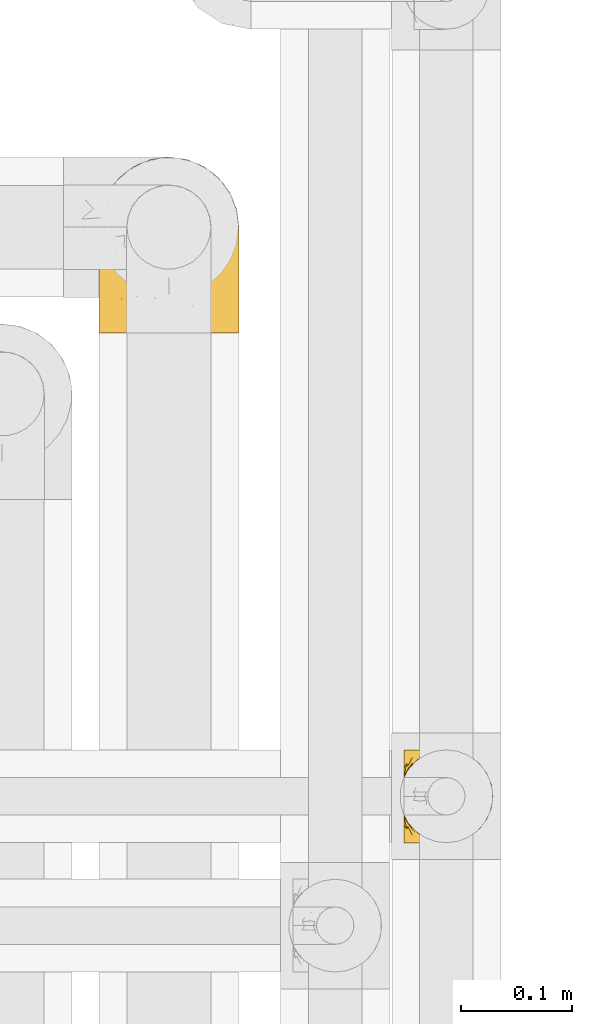
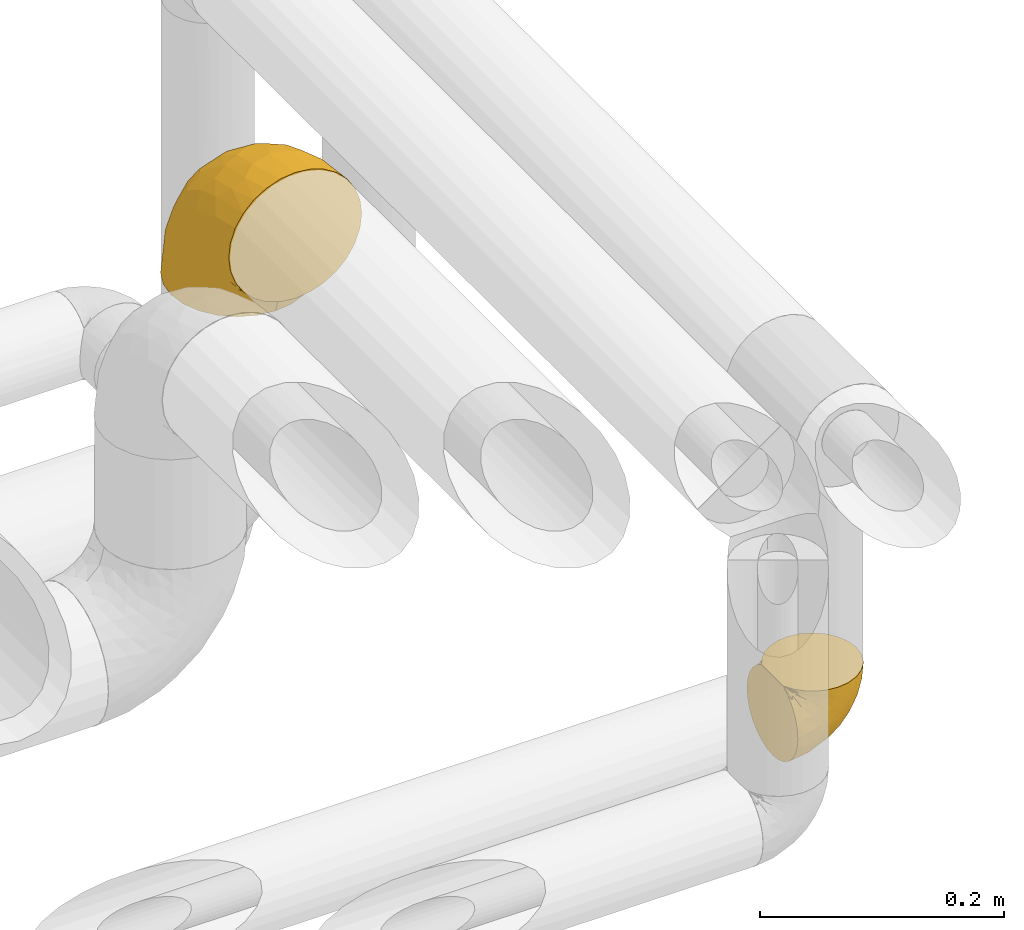
# One storey, part 493 of 827: 2 coverings.
"""IFC2X3 building model written with IfcOpenShell, lengths in millimetres."""

from ifc_helpers import new_model, entity, si_unit, converted_unit, derived_unit, direction, frame, origin, place, context, subcontext, project, spatial, faceted_brep, element, save


model = new_model("IFC2X3")

# Units and contexts
model_context = context("Model", 3, precision=0.01, world=origin(), true_north=direction((6.12303176911189e-17, 1.0)))
body_context = subcontext(model_context, "Body", "Model", "MODEL_VIEW")
ifc_project = project(units=[si_unit("LENGTHUNIT", "METRE", prefix="MILLI"), si_unit("AREAUNIT", "SQUARE_METRE"), si_unit("VOLUMEUNIT", "CUBIC_METRE"), converted_unit("PLANEANGLEUNIT", "DEGREE", entity("IfcRatioMeasure", 0.0174532925199433), si_unit("PLANEANGLEUNIT", "RADIAN"), dimensions=[0, 0, 0, 0, 0, 0, 0]), si_unit("MASSUNIT", "GRAM", prefix="KILO"), derived_unit("MASSDENSITYUNIT", [(si_unit("MASSUNIT", "GRAM", prefix="KILO"), 1), (si_unit("LENGTHUNIT", "METRE"), -3)]), derived_unit("MOMENTOFINERTIAUNIT", [(si_unit("LENGTHUNIT", "METRE"), 4)]), si_unit("TIMEUNIT", "SECOND"), si_unit("FREQUENCYUNIT", "HERTZ"), si_unit("THERMODYNAMICTEMPERATUREUNIT", "DEGREE_CELSIUS"), derived_unit("THERMALTRANSMITTANCEUNIT", [(si_unit("MASSUNIT", "GRAM", prefix="KILO"), 1), (si_unit("THERMODYNAMICTEMPERATUREUNIT", "KELVIN"), -1), (si_unit("TIMEUNIT", "SECOND"), -3)]), derived_unit("VOLUMETRICFLOWRATEUNIT", [(si_unit("LENGTHUNIT", "METRE"), 3), (si_unit("TIMEUNIT", "SECOND"), -1)]), derived_unit("MASSFLOWRATEUNIT", [(si_unit("MASSUNIT", "GRAM", prefix="KILO"), 1), (si_unit("TIMEUNIT", "SECOND"), -1)]), derived_unit("ROTATIONALFREQUENCYUNIT", [(si_unit("TIMEUNIT", "SECOND"), -1)]), si_unit("ELECTRICCURRENTUNIT", "AMPERE"), si_unit("ELECTRICVOLTAGEUNIT", "VOLT"), si_unit("POWERUNIT", "WATT"), si_unit("FORCEUNIT", "NEWTON", prefix="KILO"), si_unit("ILLUMINANCEUNIT", "LUX"), si_unit("LUMINOUSFLUXUNIT", "LUMEN"), si_unit("LUMINOUSINTENSITYUNIT", "CANDELA"), derived_unit("USERDEFINED", [(si_unit("MASSUNIT", "GRAM", prefix="KILO"), -1), (si_unit("LENGTHUNIT", "METRE"), -2), (si_unit("TIMEUNIT", "SECOND"), 3), (si_unit("LUMINOUSFLUXUNIT", "LUMEN"), 1)]), derived_unit("LINEARVELOCITYUNIT", [(si_unit("LENGTHUNIT", "METRE"), 1), (si_unit("TIMEUNIT", "SECOND"), -1)]), si_unit("PRESSUREUNIT", "PASCAL"), derived_unit("USERDEFINED", [(si_unit("LENGTHUNIT", "METRE"), -2), (si_unit("MASSUNIT", "GRAM", prefix="KILO"), 1), (si_unit("TIMEUNIT", "SECOND"), -2)]), derived_unit("LINEARFORCEUNIT", [(si_unit("MASSUNIT", "GRAM", prefix="KILO"), 1), (si_unit("LENGTHUNIT", "METRE"), 1), (si_unit("TIMEUNIT", "SECOND"), -2), (si_unit("LENGTHUNIT", "METRE"), -1)]), derived_unit("PLANARFORCEUNIT", [(si_unit("MASSUNIT", "GRAM", prefix="KILO"), 1), (si_unit("LENGTHUNIT", "METRE"), 1), (si_unit("TIMEUNIT", "SECOND"), -2), (si_unit("LENGTHUNIT", "METRE"), -2)])], contexts=[model_context])

# Site, building, storey
site_placement = place(None, origin())
site = spatial("IfcSite", under=ifc_project, at=site_placement, CompositionType="ELEMENT")
building_placement = place(site_placement, origin())
building = spatial("IfcBuilding", under=site, at=building_placement, CompositionType="ELEMENT")
storey_placement = place(building_placement, frame((0.0, 0.0, 28200.0)))
storey = spatial("IfcBuildingStorey", under=building, at=storey_placement, Name="08", CompositionType="ELEMENT", Elevation=28200.0)

# Coverings
covering_1_placement = place(storey_placement, frame((61113.04, 15517.08, 2656.55)))
element("IfcCovering", 1, at=covering_1_placement, inside=storey, Name=":ADSK_", ObjectType=":ADSK_", PredefinedType="INSULATION", context=body_context, shape_type="Brep", body=[
    faceted_brep([(1.6, 81.15, 25.28), (1.6, 76.16, 17.35), (1.6, 69.53, 10.72), (1.6, 61.6, 5.74), (1.6, 52.75, 2.64), (1.6, 43.45, 1.6), (1.6, 34.13, 2.65), (1.6, 25.28, 5.74), (1.6, 17.35, 10.73), (1.6, 10.72, 17.36), (1.6, 5.74, 25.29), (1.6, 2.64, 34.14), (1.6, 1.6, 43.45), (1.6, 2.66, 52.82), (1.6, 5.79, 61.71), (1.6, 10.83, 69.67), (1.6, 17.53, 76.31), (1.6, 25.53, 81.27), (1.6, 26.45, 81.27), (1.6, 27.37, 81.27), (1.6, 28.17, 81.27), (1.6, 29.49, 81.27), (1.6, 30.81, 81.27), (1.6, 32.13, 81.27), (1.6, 33.45, 81.27), (1.6, 34.78, 81.27), (1.6, 36.1, 81.27), (1.6, 37.42, 81.27), (1.6, 38.74, 81.27), (1.6, 40.06, 81.27), (1.6, 41.38, 81.27), (1.6, 42.7, 81.27), (1.6, 44.02, 81.27), (1.6, 45.34, 81.27), (1.6, 46.66, 81.27), (1.6, 47.58, 81.27), (1.6, 48.5, 81.27), (1.6, 49.41, 81.27), (1.6, 50.33, 81.27), (1.6, 51.25, 81.27), (1.6, 52.17, 81.27), (1.6, 53.09, 81.27), (1.6, 54.01, 81.27), (1.6, 54.93, 81.27), (1.6, 55.85, 81.27), (1.6, 56.76, 81.27), (1.6, 57.68, 81.27), (1.6, 58.6, 81.27), (1.6, 59.52, 81.27), (1.6, 60.44, 81.27), (1.6, 61.36, 81.27), (1.6, 69.37, 76.3), (1.6, 76.07, 69.66), (1.6, 81.11, 61.69), (1.6, 84.24, 52.8), (1.6, 85.3, 43.45), (1.6, 84.24, 34.13), (6.74, 17.52, 81.45), (13.37, 10.83, 81.45), (21.34, 5.79, 81.45), (30.23, 2.66, 81.45), (39.6, 1.6, 81.45), (50.43, 3.02, 81.45), (60.52, 7.2, 81.45), (69.19, 13.85, 81.45), (75.84, 22.52, 81.45), (80.02, 32.61, 81.45), (81.45, 43.45, 81.45), (80.02, 54.28, 81.45), (75.84, 64.37, 81.45), (69.19, 73.04, 81.45), (60.52, 79.69, 81.45), (50.43, 83.87, 81.45), (39.6, 85.3, 81.45), (30.23, 84.23, 81.45), (21.34, 81.1, 81.45), (13.37, 76.06, 81.45), (6.74, 69.37, 81.45), (1.77, 61.36, 81.45), (1.77, 60.44, 81.45), (1.77, 59.12, 81.45), (1.77, 58.0, 81.45), (1.77, 56.88, 81.45), (1.77, 55.76, 81.45), (1.77, 54.64, 81.45), (1.77, 53.52, 81.45), (1.77, 52.4, 81.45), (1.77, 51.28, 81.45), (1.77, 50.16, 81.45), (1.77, 49.04, 81.45), (1.77, 47.92, 81.45), (1.77, 46.8, 81.45), (1.77, 45.68, 81.45), (1.77, 44.56, 81.45), (1.77, 43.45, 81.45), (1.77, 42.12, 81.45), (1.77, 40.8, 81.45), (1.77, 39.48, 81.45), (1.77, 38.16, 81.45), (1.77, 36.84, 81.45), (1.77, 35.52, 81.45), (1.77, 34.2, 81.45), (1.77, 32.88, 81.45), (1.77, 31.96, 81.45), (1.77, 31.05, 81.45), (1.77, 30.13, 81.45), (1.77, 29.21, 81.45), (1.77, 28.29, 81.45), (1.77, 27.37, 81.45), (1.77, 26.45, 81.45), (1.77, 25.53, 81.45), (1.73, 54.08, 81.33), (1.72, 55.16, 81.32), (1.73, 36.18, 81.33), (1.72, 35.13, 81.32), (1.73, 44.01, 81.33), (1.73, 45.08, 81.32), (1.72, 61.36, 81.32), (1.72, 59.98, 81.32), (1.72, 46.18, 81.32), (1.72, 26.74, 81.32), (1.72, 47.36, 81.32), (1.73, 29.67, 81.32), (1.74, 28.72, 81.34), (1.72, 39.77, 81.32), (1.71, 52.96, 81.31), (1.73, 51.84, 81.33), (1.71, 40.8, 81.31), (1.72, 41.87, 81.32), (1.73, 42.94, 81.33), (1.72, 27.77, 81.32), (1.73, 48.4, 81.33), (1.72, 37.21, 81.32), (1.73, 33.54, 81.33), (1.72, 32.49, 81.32), (1.72, 30.69, 81.32), (1.72, 50.69, 81.32), (1.71, 49.6, 81.31), (1.72, 56.32, 81.32), (1.73, 57.44, 81.33), (1.71, 58.88, 81.31), (1.72, 25.53, 81.32), (1.68, 61.36, 81.3), (1.64, 61.36, 81.29), (1.64, 25.53, 81.29), (1.68, 25.53, 81.3), (1.75, 61.36, 81.4), (1.74, 61.36, 81.36), (1.74, 25.53, 81.36), (1.75, 25.53, 81.4), (1.7, 31.59, 81.3), (1.73, 38.71, 81.33), (24.54, 3.97, 74.06), (11.1, 1.6, 45.99), (8.47, 3.97, 58.35), (9.11, 8.09, 67.76), (4.86, 8.09, 66.18), (5.0, 16.43, 76.46), (6.81, 15.73, 77.33), (37.05, 1.6, 71.95), (9.03, 10.79, 72.25), (9.47, 13.99, 78.91), (16.39, 8.08, 76.42), (3.95, 14.0, 73.52), (9.9, 12.83, 76.9), (22.7, 3.18, 65.25), (34.5, 1.6, 62.45), (37.68, 1.6, 74.31), (15.82, 3.28, 59.38), (20.6, 1.6, 48.54), (14.37, 6.28, 67.72), (27.55, 1.6, 55.49), (5.2, 19.06, 79.73), (14.88, 8.08, 73.23), (8.73, 1.6, 45.36), (44.27, 32.11, 15.81), (20.94, 29.62, 6.4), (32.15, 43.45, 7.67), (46.13, 2.45, 68.46), (42.67, 2.5, 59.33), (55.18, 9.73, 48.7), (67.27, 17.97, 53.94), (62.91, 10.24, 65.02), (51.5, 4.78, 60.77), (54.79, 4.78, 72.07), (25.78, 8.01, 26.25), (13.05, 8.01, 22.29), (18.46, 13.85, 16.0), (32.4, 2.42, 46.93), (31.07, 21.17, 14.19), (77.32, 35.73, 58.46), (75.62, 27.43, 61.51), (16.9, 43.45, 4.64), (71.69, 17.97, 68.93), (61.4, 35.71, 29.62), (54.47, 29.47, 24.85), (27.66, 3.41, 38.55), (14.53, 3.94, 31.27), (15.56, 21.17, 9.35), (42.26, 7.92, 37.15), (41.51, 4.25, 47.07), (36.93, 11.75, 26.49), (42.72, 18.31, 23.01), (44.68, 24.94, 19.4), (71.2, 28.78, 48.06), (70.48, 35.82, 42.46), (75.37, 43.45, 50.89), (63.65, 28.38, 35.78), (58.06, 43.45, 24.98), (45.11, 43.45, 16.33), (78.4, 43.45, 66.14), (54.95, 21.21, 30.96), (59.31, 16.48, 41.83), (49.01, 13.85, 33.28), (66.71, 43.45, 37.94), (53.75, 82.11, 67.39), (77.27, 51.41, 58.47), (61.6, 57.45, 32.5), (44.24, 54.78, 15.79), (18.46, 73.03, 15.99), (15.55, 65.7, 9.34), (60.14, 76.65, 56.91), (70.5, 68.92, 63.5), (63.0, 68.01, 44.08), (25.78, 78.88, 26.24), (13.05, 78.88, 22.27), (14.53, 82.94, 31.26), (48.5, 64.44, 23.95), (44.23, 84.49, 63.79), (34.5, 85.3, 62.45), (37.05, 85.3, 71.95), (8.73, 85.3, 45.36), (77.68, 57.84, 67.83), (64.08, 76.65, 70.28), (70.25, 51.19, 42.11), (20.93, 57.26, 6.39), (49.9, 78.14, 43.54), (49.6, 82.35, 58.03), (31.06, 65.7, 14.18), (39.62, 84.61, 56.34), (34.42, 84.36, 48.09), (20.6, 85.3, 48.54), (27.55, 85.3, 55.49), (33.36, 73.03, 21.78), (27.68, 83.48, 38.54), (11.1, 85.3, 45.99), (46.67, 84.54, 72.79), (49.0, 73.03, 33.26), (38.94, 79.54, 35.53), (73.05, 59.46, 53.66), (56.63, 73.5, 43.03), (43.85, 82.57, 49.68), (24.54, 82.92, 74.06), (15.82, 83.62, 59.37), (8.47, 82.92, 58.34), (9.12, 78.81, 67.75), (9.47, 72.9, 78.91), (9.91, 74.06, 76.9), (16.85, 78.81, 78.08), (14.88, 78.81, 73.23), (5.2, 67.83, 79.73), (6.81, 71.15, 77.34), (3.96, 72.91, 73.51), (5.0, 70.47, 76.45), (5.86, 78.81, 66.41), (14.38, 80.62, 67.7), (9.04, 76.11, 72.24), (22.7, 83.71, 65.25)], [[[0, 1, 2, 3, 4, 5, 6, 7, 8, 9, 10, 11, 12, 13, 14, 15, 16, 17, 18, 19, 20, 21, 22, 23, 24, 25, 26, 27, 28, 29, 30, 31, 32, 33, 34, 35, 36, 37, 38, 39, 40, 41, 42, 43, 44, 45, 46, 47, 48, 49, 50, 51, 52, 53, 54, 55, 56]], [[57, 58, 59, 60, 61, 62, 63, 64, 65, 66, 67, 68, 69, 70, 71, 72, 73, 74, 75, 76, 77, 78, 79, 80, 81, 82, 83, 84, 85, 86, 87, 88, 89, 90, 91, 92, 93, 94, 95, 96, 97, 98, 99, 100, 101, 102, 103, 104, 105, 106, 107, 108, 109, 110]], [[111, 84, 112]], [[113, 26, 114]], [[114, 101, 100]], [[115, 93, 116]], [[79, 117, 118]], [[33, 116, 119]], [[117, 49, 118]], [[19, 18, 120]], [[119, 121, 34]], [[122, 21, 123]], [[97, 96, 124]], [[86, 125, 126]], [[116, 92, 119]], [[127, 96, 128]], [[32, 129, 115]], [[19, 120, 130]], [[121, 90, 131]], [[94, 115, 129]], [[115, 116, 32]], [[118, 49, 48]], [[113, 99, 132]], [[133, 114, 25]], [[24, 134, 133]], [[135, 22, 122]], [[136, 137, 88]], [[84, 83, 112]], [[138, 82, 139]], [[130, 20, 19]], [[118, 48, 140]], [[81, 140, 139]], [[123, 21, 20]], [[141, 120, 18]], [[139, 82, 81]], [[130, 107, 123]], [[49, 117, 142, 143, 50]], [[18, 17, 144, 145, 141]], [[79, 78, 146, 147, 117]], [[109, 141, 148, 149, 110]], [[102, 133, 134]], [[105, 135, 122]], [[118, 80, 79]], [[80, 118, 140]], [[120, 109, 108]], [[47, 46, 140, 48]], [[81, 80, 140]], [[44, 112, 138]], [[93, 115, 94]], [[46, 139, 140]], [[46, 45, 139]], [[139, 45, 138]], [[138, 112, 83]], [[85, 84, 111]], [[112, 43, 111]], [[83, 82, 138]], [[106, 122, 123]], [[105, 122, 106]], [[21, 122, 22]], [[124, 29, 28]], [[33, 32, 116]], [[128, 129, 31]], [[32, 31, 129]], [[34, 33, 119]], [[116, 93, 92]], [[129, 95, 94]], [[95, 129, 128]], [[41, 40, 125, 42]], [[119, 91, 121]], [[36, 35, 131, 37]], [[137, 131, 89]], [[121, 131, 35]], [[90, 121, 91]], [[119, 92, 91]], [[136, 126, 39]], [[125, 86, 85]], [[42, 125, 111]], [[85, 111, 125]], [[150, 23, 22]], [[130, 108, 107]], [[130, 123, 20]], [[107, 106, 123]], [[137, 37, 131]], [[136, 38, 137]], [[89, 88, 137]], [[131, 90, 89]], [[124, 151, 97]], [[40, 39, 126]], [[87, 126, 136]], [[86, 126, 87]], [[136, 88, 87]], [[40, 126, 125]], [[39, 38, 136]], [[95, 128, 96]], [[30, 128, 31]], [[29, 124, 127]], [[127, 128, 30]], [[151, 124, 28]], [[127, 30, 29]], [[127, 124, 96]], [[151, 98, 97]], [[45, 44, 138]], [[26, 113, 132]], [[113, 100, 99]], [[132, 151, 27]], [[27, 26, 132]], [[26, 25, 114]], [[100, 113, 114]], [[101, 133, 102]], [[133, 101, 114]], [[28, 27, 151]], [[132, 99, 98]], [[23, 134, 24]], [[25, 24, 133]], [[134, 23, 150]], [[135, 104, 150]], [[150, 104, 103]], [[103, 102, 134]], [[130, 120, 108]], [[109, 120, 141]], [[42, 111, 43]], [[112, 44, 43]], [[104, 135, 105]], [[134, 150, 103]], [[135, 150, 22]], [[35, 34, 121]], [[137, 38, 37]], [[98, 151, 132]], [[59, 152, 60]], [[13, 153, 154]], [[155, 156, 154]], [[157, 158, 141]], [[159, 60, 152]], [[160, 157, 155]], [[161, 162, 58]], [[58, 162, 59]], [[144, 16, 163]], [[58, 57, 161]], [[162, 161, 164]], [[157, 163, 155]], [[163, 16, 15]], [[57, 149, 161]], [[152, 165, 166]], [[157, 144, 163]], [[60, 159, 167, 61]], [[156, 14, 154]], [[163, 156, 155]], [[155, 154, 168]], [[168, 154, 169]], [[155, 170, 160]], [[57, 110, 149]], [[144, 17, 16]], [[156, 15, 14]], [[171, 165, 168]], [[158, 164, 172]], [[14, 13, 154]], [[157, 141, 145, 144]], [[173, 164, 158]], [[173, 160, 170]], [[171, 166, 165]], [[168, 165, 170]], [[168, 169, 171]], [[152, 173, 165]], [[170, 155, 168]], [[165, 173, 170]], [[160, 173, 158]], [[172, 149, 148]], [[148, 141, 158]], [[158, 157, 160]], [[152, 166, 159]], [[173, 152, 162]], [[59, 162, 152]], [[13, 12, 174, 153]], [[153, 169, 154]], [[15, 156, 163]], [[162, 164, 173]], [[172, 164, 161]], [[149, 172, 161]], [[158, 172, 148]], [[175, 176, 177]], [[178, 166, 179]], [[180, 181, 182]], [[183, 184, 178]], [[185, 186, 187]], [[171, 188, 179]], [[174, 12, 11]], [[189, 176, 175]], [[190, 66, 191]], [[176, 6, 192]], [[193, 65, 64]], [[63, 184, 182]], [[63, 182, 64]], [[65, 193, 191]], [[184, 63, 62]], [[175, 194, 195]], [[196, 169, 197]], [[174, 11, 197]], [[8, 7, 198]], [[187, 9, 8]], [[197, 169, 153, 174]], [[197, 11, 10]], [[186, 197, 10]], [[199, 180, 200]], [[197, 185, 196]], [[201, 189, 202]], [[201, 187, 189]], [[195, 203, 175]], [[191, 204, 190]], [[176, 7, 6]], [[177, 176, 192]], [[189, 198, 176]], [[65, 191, 66]], [[198, 187, 8]], [[205, 206, 190]], [[9, 186, 10]], [[181, 207, 204]], [[208, 175, 177, 209]], [[66, 190, 210]], [[211, 212, 213]], [[190, 204, 205]], [[180, 182, 183]], [[193, 182, 181]], [[62, 61, 167]], [[196, 185, 199]], [[196, 200, 188]], [[6, 5, 192]], [[176, 198, 7]], [[187, 198, 189]], [[187, 186, 9]], [[197, 186, 185]], [[200, 180, 183]], [[180, 213, 212]], [[179, 183, 178]], [[185, 201, 199]], [[210, 190, 206]], [[210, 67, 66]], [[205, 204, 207]], [[194, 205, 207]], [[194, 214, 205]], [[195, 194, 207]], [[208, 194, 175]], [[207, 211, 195]], [[202, 203, 211]], [[212, 207, 181]], [[202, 211, 213]], [[201, 202, 213]], [[189, 175, 203]], [[199, 201, 213]], [[187, 201, 185]], [[180, 199, 213]], [[196, 199, 200]], [[211, 203, 195]], [[189, 203, 202]], [[207, 212, 211]], [[180, 212, 181]], [[214, 194, 208]], [[214, 206, 205]], [[196, 188, 169]], [[181, 204, 191]], [[182, 193, 64]], [[191, 193, 181]], [[178, 62, 167]], [[182, 184, 183]], [[62, 178, 184]], [[178, 167, 159, 166]], [[171, 179, 166]], [[200, 183, 179]], [[179, 188, 200]], [[169, 188, 171]], [[71, 215, 72]], [[206, 216, 210]], [[217, 208, 218]], [[216, 68, 210]], [[219, 220, 2]], [[221, 222, 223]], [[224, 225, 226]], [[227, 223, 217]], [[228, 229, 230]], [[56, 231, 226]], [[232, 222, 69]], [[56, 55, 231]], [[70, 233, 71]], [[71, 233, 215]], [[0, 56, 226]], [[208, 217, 234]], [[218, 177, 235]], [[221, 236, 237]], [[238, 220, 219]], [[1, 219, 2]], [[68, 216, 232]], [[235, 3, 220]], [[235, 192, 4]], [[1, 0, 225]], [[228, 239, 229]], [[240, 241, 242]], [[243, 238, 219]], [[224, 226, 244]], [[226, 241, 244]], [[3, 235, 4]], [[69, 222, 70]], [[225, 219, 1]], [[218, 235, 238]], [[243, 219, 224]], [[218, 227, 217]], [[3, 2, 220]], [[218, 208, 209, 177]], [[226, 231, 245, 241]], [[215, 228, 246]], [[247, 248, 236]], [[248, 224, 244]], [[223, 222, 249]], [[233, 222, 221]], [[242, 239, 240]], [[248, 247, 243]], [[217, 223, 249]], [[250, 247, 236]], [[216, 234, 249]], [[218, 238, 227]], [[192, 235, 177]], [[192, 5, 4]], [[72, 246, 73]], [[235, 220, 238]], [[226, 225, 0]], [[219, 225, 224]], [[240, 248, 244]], [[239, 242, 229]], [[236, 248, 251]], [[68, 67, 210]], [[234, 216, 206]], [[216, 249, 232]], [[234, 206, 214, 208]], [[249, 234, 217]], [[222, 232, 249]], [[69, 68, 232]], [[246, 228, 230]], [[237, 228, 215]], [[243, 227, 238]], [[223, 227, 247]], [[73, 246, 230]], [[215, 246, 72]], [[248, 243, 224]], [[227, 243, 247]], [[237, 236, 251]], [[250, 221, 223]], [[222, 233, 70]], [[215, 233, 221]], [[221, 237, 215]], [[239, 237, 251]], [[237, 239, 228]], [[239, 251, 240]], [[248, 240, 251]], [[241, 240, 244]], [[221, 250, 236]], [[223, 247, 250]], [[74, 230, 252]], [[253, 254, 255]], [[146, 77, 256]], [[257, 258, 259]], [[260, 256, 257]], [[260, 261, 147]], [[75, 74, 252]], [[51, 143, 262]], [[263, 143, 142, 117]], [[256, 77, 76]], [[252, 258, 75]], [[253, 241, 254]], [[254, 245, 54]], [[258, 256, 76]], [[53, 52, 264]], [[255, 265, 253]], [[254, 264, 255]], [[255, 264, 262]], [[75, 258, 76]], [[265, 255, 266]], [[255, 262, 263]], [[51, 50, 143]], [[54, 245, 231, 55]], [[51, 262, 52]], [[253, 267, 242]], [[254, 54, 53]], [[266, 259, 265]], [[146, 78, 77]], [[263, 117, 261]], [[146, 256, 260]], [[257, 259, 261]], [[267, 253, 265]], [[229, 267, 252]], [[242, 267, 229]], [[242, 241, 253]], [[252, 267, 259]], [[255, 263, 266]], [[259, 267, 265]], [[261, 117, 147]], [[263, 261, 266]], [[259, 266, 261]], [[230, 74, 73]], [[230, 229, 252]], [[259, 258, 252]], [[254, 241, 245]], [[53, 264, 254]], [[52, 262, 264]], [[143, 263, 262]], [[258, 257, 256]], [[261, 260, 257]], [[146, 260, 147]]]),
])
covering_2_placement = place(storey_placement, frame((60838.46, 15975.78, 2903.4)))
element("IfcCovering", 2, at=covering_2_placement, inside=storey, Name=":ADSK_", ObjectType=":ADSK_", PredefinedType="INSULATION", context=body_context, shape_type="Brep", body=[
    faceted_brep([(92.0, 1.6, 153.4), (78.68, 1.6, 158.06), (64.65, 1.6, 159.65), (50.62, 1.6, 158.06), (37.29, 1.6, 153.4), (25.34, 1.6, 145.89), (15.35, 1.6, 135.91), (7.84, 1.6, 123.95), (3.18, 1.6, 110.63), (1.6, 1.6, 96.6), (3.18, 1.6, 82.57), (7.84, 1.6, 69.24), (15.35, 1.6, 57.29), (25.33, 1.6, 47.3), (37.29, 1.6, 39.79), (50.61, 1.6, 35.13), (64.65, 1.6, 33.55), (78.67, 1.6, 35.13), (92.0, 1.6, 39.79), (103.95, 1.6, 47.3), (113.94, 1.6, 57.28), (121.45, 1.6, 69.24), (126.11, 1.6, 82.56), (127.7, 1.6, 96.6), (126.11, 1.6, 110.62), (121.45, 1.6, 123.95), (113.94, 1.6, 135.9), (103.96, 1.6, 145.89), (64.65, 33.55, 1.6), (48.33, 35.69, 1.6), (33.12, 41.99, 1.6), (20.06, 52.01, 1.6), (10.04, 65.07, 1.6), (3.74, 80.28, 1.6), (3.01, 85.89, 1.6), (1.6, 96.6, 1.6), (3.74, 112.91, 1.6), (10.04, 128.12, 1.6), (20.06, 141.18, 1.6), (33.12, 151.2, 1.6), (48.33, 157.5, 1.6), (64.65, 159.65, 1.6), (80.96, 157.5, 1.6), (96.17, 151.2, 1.6), (109.23, 141.18, 1.6), (119.25, 128.12, 1.6), (125.55, 112.91, 1.6), (127.7, 96.6, 1.6), (126.29, 85.89, 1.6), (125.55, 80.28, 1.6), (119.25, 65.07, 1.6), (109.23, 52.01, 1.6), (96.17, 41.99, 1.6), (80.96, 35.69, 1.6), (101.1, 145.23, 30.13), (86.72, 150.95, 39.4), (98.7, 136.48, 62.65), (75.93, 156.3, 28.52), (64.65, 154.26, 42.5), (113.39, 73.92, 115.57), (111.06, 98.94, 98.94), (96.87, 102.72, 111.29), (84.07, 124.89, 95.5), (64.65, 138.47, 80.62), (64.65, 113.35, 113.35), (119.56, 120.33, 43.71), (112.75, 118.42, 70.76), (122.85, 103.99, 62.71), (125.08, 110.05, 33.16), (126.64, 94.6, 53.41), (105.78, 62.68, 130.65), (93.81, 66.8, 137.68), (96.07, 37.71, 146.84), (87.11, 141.12, 66.58), (75.77, 148.29, 57.7), (111.99, 132.76, 39.88), (64.65, 42.5, 154.26), (83.58, 39.36, 152.07), (80.96, 96.16, 125.54), (78.34, 69.16, 142.81), (122.85, 62.71, 103.99), (125.88, 79.4, 79.4), (120.97, 88.81, 88.81), (126.67, 26.93, 104.86), (122.64, 32.13, 117.38), (127.7, 78.45, 57.43), (127.7, 85.2, 44.19), (127.7, 91.95, 30.95), (107.12, 31.66, 139.96), (115.07, 45.38, 127.03), (102.81, 118.88, 87.17), (127.7, 57.43, 78.45), (127.7, 62.69, 73.2), (127.7, 67.94, 67.94), (127.7, 13.99, 94.63), (127.7, 22.47, 93.29), (127.7, 30.95, 91.95), (126.64, 53.41, 94.6), (127.7, 44.19, 85.2), (64.65, 80.62, 138.47), (127.7, 94.63, 13.99), (113.05, 39.95, 40.46), (101.81, 33.15, 32.36), (108.46, 43.2, 28.71), (126.21, 81.77, 15.53), (122.65, 66.3, 29.06), (126.55, 75.23, 40.03), (125.45, 66.55, 45.36), (126.01, 78.18, 26.46), (123.3, 56.85, 47.56), (118.99, 54.23, 36.28), (113.51, 12.94, 55.57), (104.6, 17.42, 45.02), (118.04, 27.05, 57.55), (101.6, 44.37, 11.56), (109.98, 49.66, 19.2), (92.1, 38.88, 10.07), (96.28, 37.08, 21.04), (121.05, 66.96, 15.52), (79.4, 32.99, 13.84), (79.19, 14.52, 32.67), (80.39, 26.32, 24.86), (93.14, 22.37, 34.31), (126.75, 27.96, 81.47), (125.71, 39.47, 71.26), (126.17, 15.41, 81.64), (64.65, 17.57, 29.26), (123.28, 21.31, 70.65), (64.65, 7.61, 31.93), (91.58, 28.92, 27.99), (107.1, 28.65, 41.71), (116.28, 34.82, 50.14), (116.32, 58.27, 17.57), (90.34, 11.73, 37.62), (122.74, 40.36, 60.48), (64.65, 29.26, 17.57), (126.77, 65.12, 56.96), (119.84, 45.4, 48.98), (124.71, 53.05, 57.29), (126.47, 50.39, 68.25), (37.19, 38.88, 10.07), (27.66, 42.9, 16.58), (49.9, 32.99, 13.84), (1.6, 94.63, 13.99), (50.1, 14.52, 32.67), (48.89, 26.32, 24.86), (2.88, 50.51, 67.81), (6.55, 39.41, 61.09), (3.58, 39.47, 71.26), (1.6, 78.45, 57.43), (1.6, 85.2, 44.19), (2.74, 75.23, 40.03), (11.25, 27.05, 57.55), (11.93, 36.34, 51.01), (21.09, 28.89, 42.79), (3.28, 78.18, 26.46), (6.64, 66.3, 29.06), (12.97, 58.27, 17.57), (19.31, 49.66, 19.2), (16.23, 39.95, 40.46), (21.44, 42.42, 28.84), (26.96, 32.56, 33.48), (8.24, 66.96, 15.52), (3.08, 81.77, 15.53), (10.3, 54.23, 36.28), (38.95, 11.73, 37.62), (33.01, 37.08, 21.04), (1.6, 13.99, 94.63), (1.6, 22.47, 93.29), (36.15, 22.37, 34.31), (24.69, 17.42, 45.03), (6.01, 21.32, 70.65), (2.54, 27.96, 81.47), (15.78, 12.94, 55.58), (1.6, 30.95, 91.95), (3.12, 15.41, 81.64), (37.33, 29.3, 27.86), (1.6, 57.43, 78.45), (1.6, 44.19, 85.2), (2.52, 65.12, 56.96), (3.84, 66.55, 45.36), (5.99, 56.85, 47.57), (9.35, 46.41, 48.27), (1.6, 67.94, 67.94), (4.58, 53.04, 57.3), (1.6, 91.95, 30.95), (30.59, 136.48, 62.65), (28.19, 145.23, 30.13), (17.3, 132.76, 39.88), (9.73, 120.33, 43.71), (42.57, 150.95, 39.4), (53.51, 149.01, 55.79), (53.42, 156.33, 28.41), (2.65, 94.6, 53.41), (2.62, 26.93, 104.86), (6.66, 32.14, 117.39), (6.44, 62.71, 103.99), (48.33, 96.16, 125.54), (32.42, 102.72, 111.29), (35.49, 66.79, 137.69), (2.65, 53.41, 94.6), (3.41, 79.4, 79.4), (4.21, 110.05, 33.16), (43.07, 140.44, 68.78), (23.52, 62.68, 130.66), (22.18, 31.66, 139.97), (33.1, 29.31, 148.6), (15.9, 73.92, 115.58), (14.23, 45.39, 127.03), (16.54, 118.42, 70.76), (45.22, 124.89, 95.5), (6.44, 103.99, 62.71), (8.33, 88.81, 88.81), (18.23, 98.94, 98.94), (32.99, 122.85, 89.09), (53.35, 138.38, 78.72), (48.76, 69.18, 142.21), (45.72, 39.36, 152.07)], [[[0, 1, 2, 3, 4, 5, 6, 7, 8, 9, 10, 11, 12, 13, 14, 15, 16, 17, 18, 19, 20, 21, 22, 23, 24, 25, 26, 27]], [[28, 29, 30, 31, 32, 33, 34, 35, 36, 37, 38, 39, 40, 41, 42, 43, 44, 45, 46, 47, 48, 49, 50, 51, 52, 53]], [[54, 55, 56]], [[57, 41, 58]], [[59, 60, 61]], [[62, 63, 64]], [[65, 66, 67]], [[68, 67, 69]], [[70, 71, 72]], [[55, 73, 56]], [[43, 42, 55]], [[55, 74, 73]], [[44, 75, 45]], [[44, 43, 54]], [[76, 1, 77]], [[71, 78, 79]], [[45, 75, 65]], [[46, 68, 47]], [[80, 81, 82]], [[24, 83, 84]], [[69, 85, 86, 87]], [[69, 81, 85]], [[84, 25, 24]], [[26, 88, 27]], [[0, 27, 72]], [[44, 54, 75]], [[1, 0, 77]], [[89, 26, 25]], [[72, 27, 88]], [[1, 76, 2]], [[70, 88, 89]], [[68, 65, 67]], [[88, 26, 89]], [[56, 90, 66]], [[64, 78, 62]], [[81, 91, 92, 93, 85]], [[83, 23, 94, 95, 96]], [[62, 61, 90]], [[97, 96, 98, 91]], [[80, 97, 81]], [[42, 57, 55]], [[62, 78, 61]], [[84, 89, 25]], [[78, 64, 99]], [[57, 74, 55]], [[76, 77, 79]], [[77, 72, 71]], [[82, 81, 67]], [[97, 83, 96]], [[80, 89, 84]], [[79, 78, 99]], [[71, 70, 61]], [[81, 97, 91]], [[83, 80, 84]], [[68, 87, 100, 47]], [[81, 69, 67]], [[68, 69, 87]], [[65, 46, 45]], [[65, 68, 46]], [[66, 65, 75]], [[56, 66, 75]], [[66, 60, 82]], [[71, 61, 78]], [[60, 66, 90]], [[83, 97, 80]], [[23, 83, 24]], [[59, 70, 89]], [[70, 59, 61]], [[89, 80, 59]], [[82, 59, 80]], [[55, 54, 43]], [[75, 54, 56]], [[66, 82, 67]], [[59, 82, 60]], [[41, 57, 42]], [[74, 57, 58]], [[58, 63, 74]], [[62, 74, 63]], [[74, 62, 73]], [[62, 56, 73]], [[0, 72, 77]], [[70, 72, 88]], [[76, 79, 99]], [[71, 79, 77]], [[62, 90, 56]], [[60, 90, 61]], [[101, 102, 103]], [[100, 87, 104]], [[105, 106, 107]], [[108, 104, 87]], [[107, 109, 110]], [[108, 87, 86]], [[111, 112, 113]], [[114, 51, 115]], [[116, 114, 117]], [[51, 50, 118]], [[119, 28, 53]], [[120, 121, 122]], [[98, 123, 124]], [[125, 96, 95]], [[116, 53, 52]], [[126, 121, 120]], [[104, 108, 118]], [[98, 124, 91]], [[21, 20, 127]], [[120, 128, 126]], [[122, 129, 102]], [[95, 94, 23, 22]], [[122, 102, 130]], [[125, 127, 123]], [[20, 111, 127]], [[17, 16, 128]], [[112, 130, 131]], [[48, 47, 100, 49]], [[132, 110, 115]], [[19, 111, 20]], [[129, 119, 117]], [[120, 133, 17]], [[112, 19, 18]], [[134, 113, 131]], [[121, 126, 135]], [[133, 112, 18]], [[128, 120, 17]], [[132, 51, 118]], [[120, 122, 133]], [[119, 121, 135]], [[129, 117, 102]], [[125, 22, 21]], [[22, 125, 95]], [[127, 125, 21]], [[28, 119, 135]], [[119, 53, 116]], [[127, 113, 124]], [[96, 125, 123]], [[112, 131, 113]], [[101, 103, 110]], [[85, 93, 136]], [[124, 123, 127]], [[98, 96, 123]], [[112, 111, 19]], [[127, 111, 113]], [[112, 133, 122]], [[17, 133, 18]], [[107, 110, 105]], [[110, 109, 137]], [[86, 106, 108]], [[138, 109, 136]], [[105, 118, 108]], [[107, 106, 85]], [[104, 50, 49]], [[124, 134, 139]], [[138, 93, 92]], [[92, 91, 139]], [[100, 104, 49]], [[118, 105, 132]], [[104, 118, 50]], [[110, 132, 105]], [[51, 132, 115]], [[108, 106, 105]], [[85, 106, 86]], [[114, 116, 52]], [[119, 116, 117]], [[51, 114, 52]], [[114, 115, 103]], [[117, 114, 103]], [[130, 102, 101]], [[117, 103, 102]], [[110, 103, 115]], [[130, 101, 131]], [[122, 130, 112]], [[101, 137, 131]], [[113, 134, 124]], [[137, 134, 131]], [[124, 139, 91]], [[134, 138, 139]], [[92, 139, 138]], [[110, 137, 101]], [[134, 137, 138]], [[136, 109, 107]], [[137, 109, 138]], [[85, 136, 107]], [[138, 136, 93]], [[122, 121, 129]], [[129, 121, 119]], [[30, 140, 141]], [[30, 29, 140]], [[28, 135, 142]], [[143, 35, 34, 33]], [[15, 144, 128]], [[126, 145, 135]], [[146, 147, 148]], [[149, 150, 151]], [[152, 153, 154]], [[155, 156, 151]], [[157, 31, 158]], [[159, 160, 161]], [[32, 162, 163]], [[158, 31, 30]], [[157, 164, 156]], [[126, 144, 145]], [[126, 128, 144]], [[14, 165, 15]], [[141, 166, 160]], [[10, 9, 167, 168]], [[163, 143, 33]], [[169, 165, 170]], [[14, 13, 170]], [[153, 159, 154]], [[142, 135, 145]], [[148, 171, 172]], [[159, 161, 154]], [[171, 152, 173]], [[173, 13, 12]], [[12, 11, 171]], [[158, 160, 164]], [[174, 175, 168]], [[173, 170, 13]], [[15, 128, 16]], [[174, 172, 175]], [[165, 169, 144]], [[162, 157, 156]], [[175, 172, 171]], [[144, 169, 145]], [[176, 169, 161]], [[166, 140, 142]], [[175, 171, 11]], [[168, 175, 10]], [[10, 175, 11]], [[142, 145, 176]], [[28, 142, 29]], [[148, 177, 146]], [[148, 178, 177]], [[152, 171, 148]], [[179, 180, 181]], [[164, 180, 156]], [[174, 178, 172]], [[148, 172, 178]], [[171, 173, 12]], [[170, 173, 152]], [[15, 165, 144]], [[170, 165, 14]], [[153, 182, 159]], [[146, 183, 184]], [[181, 180, 164]], [[180, 151, 156]], [[163, 155, 185]], [[155, 150, 185]], [[162, 156, 155]], [[143, 163, 185]], [[180, 179, 149]], [[32, 163, 33]], [[163, 162, 155]], [[31, 162, 32]], [[31, 157, 162]], [[164, 157, 158]], [[149, 151, 180]], [[155, 151, 150]], [[142, 140, 29]], [[141, 140, 166]], [[176, 145, 169]], [[30, 141, 158]], [[164, 160, 159]], [[158, 141, 160]], [[166, 161, 160]], [[154, 169, 170]], [[169, 154, 161]], [[152, 154, 170]], [[147, 152, 148]], [[153, 147, 182]], [[181, 182, 184]], [[164, 159, 182]], [[161, 166, 176]], [[142, 176, 166]], [[183, 146, 177]], [[184, 182, 147]], [[184, 147, 146]], [[152, 147, 153]], [[182, 181, 164]], [[179, 184, 183]], [[184, 179, 181]], [[149, 179, 183]], [[186, 187, 188]], [[37, 36, 189]], [[190, 191, 192]], [[193, 185, 150, 149]], [[194, 195, 196]], [[197, 198, 199]], [[200, 201, 177]], [[193, 202, 185]], [[203, 190, 186]], [[202, 189, 36]], [[41, 40, 192]], [[204, 205, 199]], [[5, 4, 206]], [[187, 190, 39]], [[40, 39, 190]], [[38, 37, 188]], [[207, 208, 204]], [[202, 35, 143, 185]], [[39, 38, 187]], [[195, 7, 208]], [[201, 149, 183, 177]], [[188, 189, 209]], [[197, 64, 210]], [[186, 188, 209]], [[9, 8, 194]], [[211, 201, 212]], [[8, 7, 195]], [[193, 201, 211]], [[212, 201, 196]], [[6, 208, 7]], [[213, 214, 209]], [[64, 63, 215]], [[216, 197, 199]], [[4, 217, 206]], [[3, 217, 4]], [[203, 191, 190]], [[3, 2, 76]], [[208, 205, 204]], [[205, 6, 5]], [[199, 205, 206]], [[3, 76, 217]], [[205, 208, 6]], [[216, 76, 99]], [[200, 177, 178, 174]], [[64, 197, 99]], [[63, 58, 191]], [[208, 196, 195]], [[196, 200, 194]], [[198, 197, 210]], [[216, 199, 217]], [[201, 193, 149]], [[202, 193, 211]], [[202, 211, 189]], [[35, 202, 36]], [[211, 212, 209]], [[37, 189, 188]], [[211, 209, 189]], [[213, 198, 214]], [[200, 174, 194]], [[201, 200, 196]], [[214, 198, 210]], [[213, 207, 198]], [[194, 174, 168, 167, 9]], [[195, 194, 8]], [[198, 204, 199]], [[204, 198, 207]], [[212, 207, 213]], [[196, 208, 207]], [[188, 187, 38]], [[190, 187, 186]], [[207, 212, 196]], [[209, 212, 213]], [[214, 203, 186]], [[191, 215, 63]], [[191, 203, 215]], [[192, 191, 58]], [[41, 192, 58]], [[190, 192, 40]], [[203, 210, 215]], [[64, 215, 210]], [[199, 206, 217]], [[5, 206, 205]], [[76, 216, 217]], [[99, 197, 216]], [[203, 214, 210]], [[209, 214, 186]]]),
])

save(model, "model.ifc")
